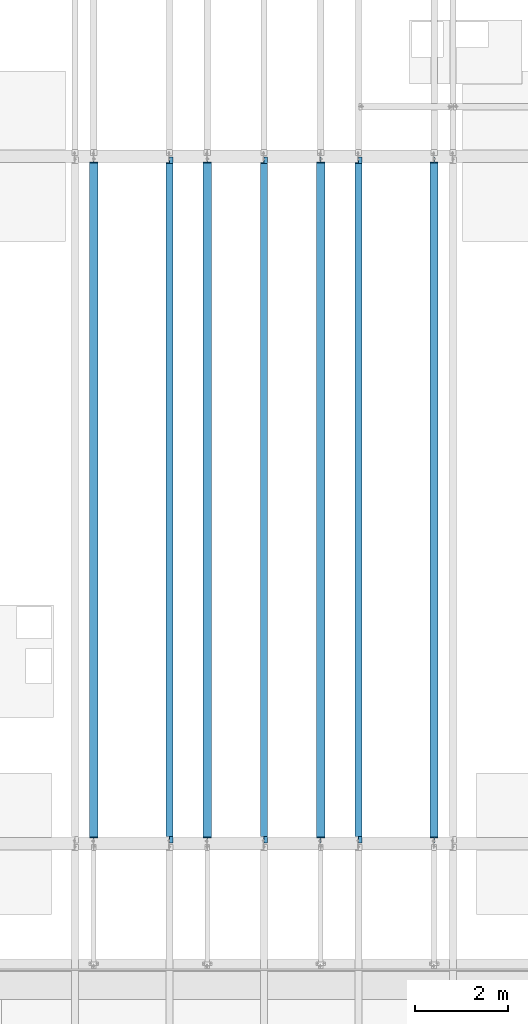
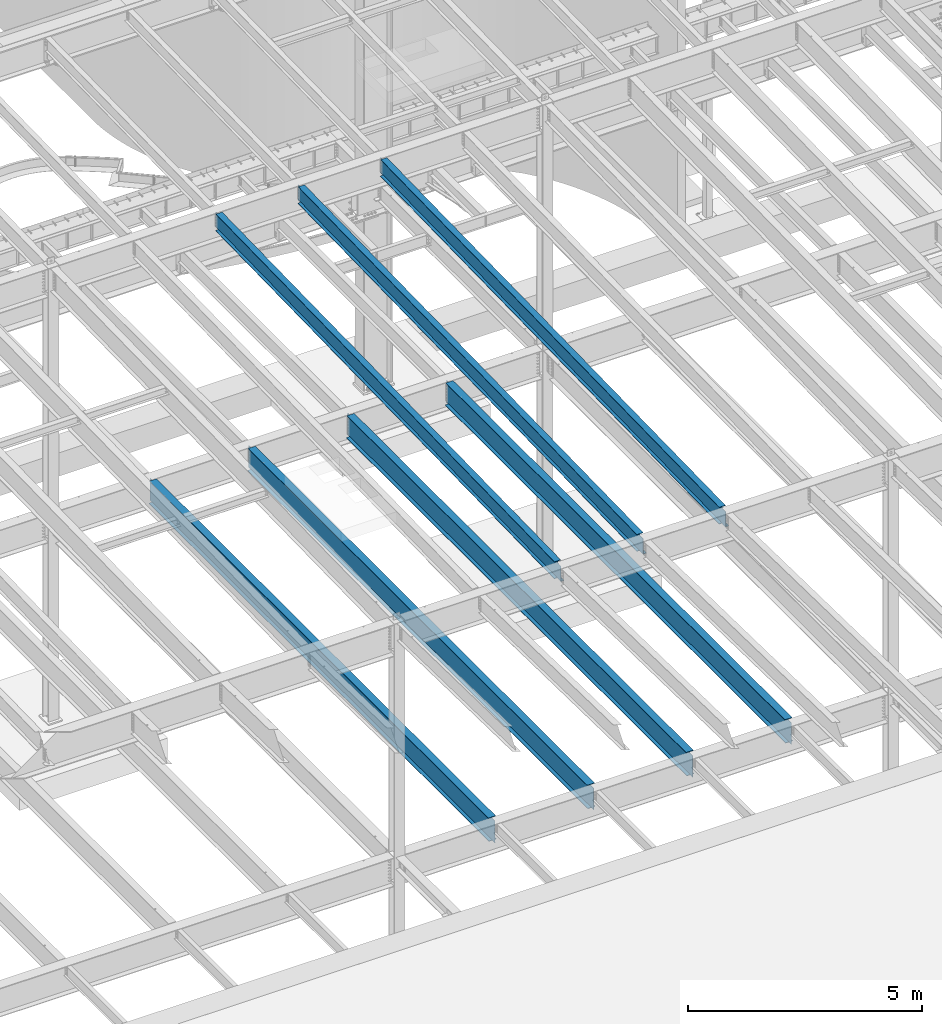
# One storey, part 1105 of 1763: 7 beams, 7 elements without a shape of their own.
"""IFC2X3 building model written with IfcOpenShell, lengths in millimetres."""

from ifc_helpers import new_model, si_unit, frame, origin_with_axes, place, context, subcontext, project, spatial, faceted_brep, material, type_object, element, aggregate, save


model = new_model("IFC2X3")

# Units and contexts
model_context = context("Model", 3, precision=1e-05, world=origin_with_axes())
body_context = subcontext(model_context, "Body", "Model", "MODEL_VIEW")
ifc_project = project(units=[si_unit("LENGTHUNIT", "METRE", prefix="MILLI"), si_unit("AREAUNIT", "SQUARE_METRE"), si_unit("VOLUMEUNIT", "CUBIC_METRE"), si_unit("MASSUNIT", "GRAM", prefix="KILO"), si_unit("TIMEUNIT", "SECOND"), si_unit("PLANEANGLEUNIT", "RADIAN"), si_unit("SOLIDANGLEUNIT", "STERADIAN"), si_unit("THERMODYNAMICTEMPERATUREUNIT", "DEGREE_CELSIUS"), si_unit("LUMINOUSINTENSITYUNIT", "LUMEN")], contexts=[model_context])

# Site, building, storey
site_placement = place(None, origin_with_axes())
site = spatial("IfcSite", under=ifc_project, at=site_placement, CompositionType="ELEMENT")
building_placement = place(site_placement, origin_with_axes())
building = spatial("IfcBuilding", under=site, at=building_placement, Name="Undefined", CompositionType="ELEMENT")
storey_placement = place(building_placement, origin_with_axes())
storey = spatial("IfcBuildingStorey", under=building, at=storey_placement, Name="Undefined", CompositionType="ELEMENT", Elevation=0.0)

# Assembly, beam
assembly_1_placement = place(storey_placement, origin_with_axes())
assembly_1 = element("IfcElementAssembly", 1, at=assembly_1_placement, inside=storey, Name="BEAM", AssemblyPlace="NOTDEFINED", PredefinedType="RIGID_FRAME")
ifc_material = material(Name="STEEL/A992")
beam_type_1 = type_object("IfcBeamType", Name="W18X35", PredefinedType="NOTDEFINED")
beam_1_placement = place(assembly_1_placement, frame((-53466.4372736983, 30027.4629676506, 11064.9232324289), z_axis=(0.0, -0.0206852279954837, 0.999786037781472), x_axis=(0.0, 0.999786037781472, 0.0206852279954825)))
beam_1 = element("IfcBeam", 2, at=beam_1_placement, type_object=beam_type_1, material=ifc_material, Name="BEAM", ObjectType="W18X35", context=body_context, shape_type="Brep", body=[
    faceted_brep([(160.440116083144, 4.26867060238874, -214.312499999869), (160.440116083122, 4.26882632548222, -225.424999999861), (9.72614572745442, 4.26881667977432, -225.424999999832), (9.95605951641846, 4.26866097140737, -214.31249999984), (160.440111479107, 76.1999999999971, -214.312499999869), (160.440111479107, 76.1999999999971, -225.424999999861), (160.440111159907, -3.96875, 187.065001487454), (160.440111159907, 3.96875, 187.065001487454), (159.47338123732, 3.96875, 182.204921969418), (159.47338123732, -3.96875, 182.204921969418), (156.720367336846, 3.96875, 178.084745501274), (156.720367336846, -3.96875, 178.084745501274), (152.600190868703, 3.96875, 175.331731600803), (152.600190868703, -3.96875, 175.331731600803), (147.740111350664, 3.96875, 174.365001678218), (147.740111350664, -3.96875, 174.365001678218), (17.9976628546319, 3.96875, 174.365001678243), (17.9976628546319, -3.96875, 174.365001678243), (9.95605951641846, -3.96875, -214.31249999984), (14757.8115434472, -3.96875, -214.312500002648), (14765.8531467846, -3.96875, 174.36500163611), (14641.5955948759, -3.96875, 174.365001636133), (14636.7355153579, -3.96875, 175.331731558719), (14632.6153388897, -3.96875, 178.084745459191), (14629.8623249892, -3.96875, 182.204921927336), (14628.8955950666, -3.96875, 187.065001445368), (14628.8955950666, -3.96875, 214.312499997053), (160.440111159915, -3.96875, 214.312499999809), (9.95605951641846, -76.1999999999971, -214.31249999984), (14757.8115434472, -76.1999999999971, -214.312500002648), (9.72614572745442, -76.1999999999971, -225.424999999832), (14757.5816296582, -76.1999999999971, -225.425000002639), (14641.5955921487, 4.26882640406257, -214.312500002627), (14641.5955921487, 4.26867068048159, -225.425000002617), (14641.5955830855, 76.1999999999971, -225.425000002617), (14641.5955830855, 76.1999999999971, -214.312500002628), (14757.8115434472, 4.26884104704368, -214.312500002648), (14757.5816296582, 4.26868529446074, -225.425000002639), (14757.8115434472, 3.96875, -214.312500002648), (14765.8531467846, 3.96875, 174.36500163611), (14641.5955948759, 3.96875, 174.365001636133), (14636.7355153579, 3.96875, 175.331731558719), (14632.6153388897, 3.96875, 178.084745459191), (14629.8623249892, 3.96875, 182.204921927336), (14628.8955950666, 3.96875, 187.065001445368), (14628.8955950666, -76.1999999999971, 225.424999997045), (14628.8955950666, -76.1999999999971, 214.312499997053), (14628.8955950666, 3.96875, 214.312499997053), (14628.8955950666, 76.1999999999971, 214.312499997053), (14628.8955950666, 76.1999999999971, 225.424999997045), (160.440111159915, 3.96875, 214.312499999809), (160.440111159915, 76.1999999999971, 214.312499999809), (160.440111159915, 76.1999999999971, 225.424999999799), (160.440111159915, -76.1999999999971, 225.424999999799), (160.440111159915, -76.1999999999971, 214.312499999809), (9.95605951641846, 3.96875, -214.31249999984)], [[[0, 1, 2, 3]], [[4, 5, 1, 0]], [[6, 7, 8, 9]], [[9, 8, 10, 11]], [[11, 10, 12, 13]], [[13, 12, 14, 15]], [[15, 14, 16, 17]], [[9, 11, 13, 15, 17, 18, 19, 20, 21, 22, 23, 24, 25, 26, 27, 6]], [[18, 28, 29, 19]], [[28, 30, 31, 29]], [[32, 33, 34, 35]], [[36, 37, 33, 32]], [[38, 39, 20, 19, 29, 31, 37, 36]], [[20, 39, 40, 21]], [[21, 40, 41, 22]], [[22, 41, 42, 23]], [[23, 42, 43, 24]], [[24, 43, 44, 25]], [[45, 46, 26, 25, 44, 47, 48, 49]], [[48, 47, 50, 51]], [[49, 48, 51, 52]], [[45, 49, 52, 53]], [[46, 45, 53, 54]], [[26, 46, 54, 27]], [[53, 52, 51, 50, 7, 6, 27, 54]], [[47, 44, 43, 42, 41, 40, 39, 38, 55, 16, 14, 12, 10, 8, 7, 50]], [[30, 28, 18, 17, 16, 55, 3, 2]], [[34, 33, 37, 31, 30, 2, 1, 5]], [[35, 34, 5, 4]], [[55, 38, 36, 32, 35, 4, 0, 3]]]),
])
aggregate(assembly_1, [beam_1])

assembly_2_placement = place(storey_placement, origin_with_axes())
assembly_2 = element("IfcElementAssembly", 3, at=assembly_2_placement, inside=storey, Name="BEAM", AssemblyPlace="NOTDEFINED", PredefinedType="RIGID_FRAME")
beam_2_placement = place(assembly_2_placement, frame((-55498.4372736983, 30027.4629676506, 11064.9232324289), z_axis=(0.0, -0.0206852279954837, 0.999786037781472), x_axis=(0.0, 0.999786037781472, 0.0206852279954825)))
beam_2 = element("IfcBeam", 4, at=beam_2_placement, type_object=beam_type_1, material=ifc_material, Name="BEAM", ObjectType="W18X35", context=body_context, shape_type="Brep", body=[
    faceted_brep([(160.440116083144, 4.26867060238874, -214.312499999869), (160.440116083122, 4.26882632548222, -225.424999999861), (9.72614572745442, 4.26881667977432, -225.424999999832), (9.95605951641846, 4.26866097140737, -214.31249999984), (160.440111479107, 76.1999999999971, -214.312499999869), (160.440111479107, 76.1999999999971, -225.424999999861), (160.440111159907, -3.96875, 187.065001487454), (160.440111159907, 3.96875, 187.065001487454), (159.47338123732, 3.96875, 182.204921969418), (159.47338123732, -3.96875, 182.204921969418), (156.720367336846, 3.96875, 178.084745501274), (156.720367336846, -3.96875, 178.084745501274), (152.600190868703, 3.96875, 175.331731600803), (152.600190868703, -3.96875, 175.331731600803), (147.740111350664, 3.96875, 174.365001678218), (147.740111350664, -3.96875, 174.365001678218), (17.9976628546319, 3.96875, 174.365001678243), (17.9976628546319, -3.96875, 174.365001678243), (9.95605951641846, -3.96875, -214.31249999984), (14757.8115434472, -3.96875, -214.312500002648), (14765.8531467846, -3.96875, 174.36500163611), (14641.5955948759, -3.96875, 174.365001636133), (14636.7355153579, -3.96875, 175.331731558719), (14632.6153388897, -3.96875, 178.084745459191), (14629.8623249892, -3.96875, 182.204921927336), (14628.8955950666, -3.96875, 187.065001445368), (14628.8955950666, -3.96875, 214.312499997053), (160.440111159915, -3.96875, 214.312499999809), (9.95605951641846, -76.1999999999971, -214.31249999984), (14757.8115434472, -76.1999999999971, -214.312500002648), (9.72614572745442, -76.1999999999971, -225.424999999832), (14757.5816296582, -76.1999999999971, -225.425000002639), (14641.5955921487, 4.26882640406257, -214.312500002627), (14641.5955921487, 4.26867068048159, -225.425000002617), (14641.5955830855, 76.1999999999971, -225.425000002617), (14641.5955830855, 76.1999999999971, -214.312500002628), (14757.8115434472, 4.26884104704368, -214.312500002648), (14757.5816296582, 4.26868529446074, -225.425000002639), (14757.8115434472, 3.96875, -214.312500002648), (14765.8531467846, 3.96875, 174.36500163611), (14641.5955948759, 3.96875, 174.365001636133), (14636.7355153579, 3.96875, 175.331731558719), (14632.6153388897, 3.96875, 178.084745459191), (14629.8623249892, 3.96875, 182.204921927336), (14628.8955950666, 3.96875, 187.065001445368), (14628.8955950666, -76.1999999999971, 225.424999997045), (14628.8955950666, -76.1999999999971, 214.312499997053), (14628.8955950666, 3.96875, 214.312499997053), (14628.8955950666, 76.1999999999971, 214.312499997053), (14628.8955950666, 76.1999999999971, 225.424999997045), (160.440111159915, 3.96875, 214.312499999809), (160.440111159915, 76.1999999999971, 214.312499999809), (160.440111159915, 76.1999999999971, 225.424999999799), (160.440111159915, -76.1999999999971, 225.424999999799), (160.440111159915, -76.1999999999971, 214.312499999809), (9.95605951641846, 3.96875, -214.31249999984)], [[[0, 1, 2, 3]], [[4, 5, 1, 0]], [[6, 7, 8, 9]], [[9, 8, 10, 11]], [[11, 10, 12, 13]], [[13, 12, 14, 15]], [[15, 14, 16, 17]], [[9, 11, 13, 15, 17, 18, 19, 20, 21, 22, 23, 24, 25, 26, 27, 6]], [[18, 28, 29, 19]], [[28, 30, 31, 29]], [[32, 33, 34, 35]], [[36, 37, 33, 32]], [[38, 39, 20, 19, 29, 31, 37, 36]], [[20, 39, 40, 21]], [[21, 40, 41, 22]], [[22, 41, 42, 23]], [[23, 42, 43, 24]], [[24, 43, 44, 25]], [[45, 46, 26, 25, 44, 47, 48, 49]], [[48, 47, 50, 51]], [[49, 48, 51, 52]], [[45, 49, 52, 53]], [[46, 45, 53, 54]], [[26, 46, 54, 27]], [[53, 52, 51, 50, 7, 6, 27, 54]], [[47, 44, 43, 42, 41, 40, 39, 38, 55, 16, 14, 12, 10, 8, 7, 50]], [[30, 28, 18, 17, 16, 55, 3, 2]], [[34, 33, 37, 31, 30, 2, 1, 5]], [[35, 34, 5, 4]], [[55, 38, 36, 32, 35, 4, 0, 3]]]),
])
aggregate(assembly_2, [beam_2])

assembly_3_placement = place(storey_placement, origin_with_axes())
assembly_3 = element("IfcElementAssembly", 5, at=assembly_3_placement, inside=storey, Name="BEAM", AssemblyPlace="NOTDEFINED", PredefinedType="RIGID_FRAME")
beam_3_placement = place(assembly_3_placement, frame((-57530.4372736983, 30027.4629676506, 11064.9232324289), z_axis=(0.0, -0.0206852279954837, 0.999786037781472), x_axis=(0.0, 0.999786037781472, 0.0206852279954825)))
beam_3 = element("IfcBeam", 6, at=beam_3_placement, type_object=beam_type_1, material=ifc_material, Name="BEAM", ObjectType="W18X35", context=body_context, shape_type="Brep", body=[
    faceted_brep([(160.440116083144, 4.26867060238874, -214.312499999869), (160.440116083122, 4.26882632548222, -225.424999999861), (9.72614572745442, 4.26881667977432, -225.424999999832), (9.95605951641846, 4.26866097140737, -214.31249999984), (160.440111479107, 76.1999999999971, -214.312499999869), (160.440111479107, 76.1999999999971, -225.424999999861), (160.440111159907, -3.96875, 187.065001487454), (160.440111159907, 3.96875, 187.065001487454), (159.47338123732, 3.96875, 182.204921969418), (159.47338123732, -3.96875, 182.204921969418), (156.720367336846, 3.96875, 178.084745501274), (156.720367336846, -3.96875, 178.084745501274), (152.600190868703, 3.96875, 175.331731600803), (152.600190868703, -3.96875, 175.331731600803), (147.740111350664, 3.96875, 174.365001678218), (147.740111350664, -3.96875, 174.365001678218), (17.9976628546319, 3.96875, 174.365001678243), (17.9976628546319, -3.96875, 174.365001678243), (9.95605951641846, -3.96875, -214.31249999984), (14757.8115434472, -3.96875, -214.312500002648), (14765.8531467846, -3.96875, 174.36500163611), (14641.5955948759, -3.96875, 174.365001636133), (14636.7355153579, -3.96875, 175.331731558719), (14632.6153388897, -3.96875, 178.084745459191), (14629.8623249892, -3.96875, 182.204921927336), (14628.8955950666, -3.96875, 187.065001445368), (14628.8955950666, -3.96875, 214.312499997053), (160.440111159915, -3.96875, 214.312499999809), (9.95605951641846, -76.1999999999971, -214.31249999984), (14757.8115434472, -76.1999999999971, -214.312500002648), (9.72614572745442, -76.1999999999971, -225.424999999832), (14757.5816296582, -76.1999999999971, -225.425000002639), (14641.5955921487, 4.26882640406257, -214.312500002627), (14641.5955921487, 4.26867068048159, -225.425000002617), (14641.5955830855, 76.1999999999971, -225.425000002617), (14641.5955830855, 76.1999999999971, -214.312500002628), (14757.8115434472, 4.26884104704368, -214.312500002648), (14757.5816296582, 4.26868529446074, -225.425000002639), (14757.8115434472, 3.96875, -214.312500002648), (14765.8531467846, 3.96875, 174.36500163611), (14641.5955948759, 3.96875, 174.365001636133), (14636.7355153579, 3.96875, 175.331731558719), (14632.6153388897, 3.96875, 178.084745459191), (14629.8623249892, 3.96875, 182.204921927336), (14628.8955950666, 3.96875, 187.065001445368), (14628.8955950666, -76.1999999999971, 225.424999997045), (14628.8955950666, -76.1999999999971, 214.312499997053), (14628.8955950666, 3.96875, 214.312499997053), (14628.8955950666, 76.1999999999971, 214.312499997053), (14628.8955950666, 76.1999999999971, 225.424999997045), (160.440111159915, 3.96875, 214.312499999809), (160.440111159915, 76.1999999999971, 214.312499999809), (160.440111159915, 76.1999999999971, 225.424999999799), (160.440111159915, -76.1999999999971, 225.424999999799), (160.440111159915, -76.1999999999971, 214.312499999809), (9.95605951641846, 3.96875, -214.31249999984)], [[[0, 1, 2, 3]], [[4, 5, 1, 0]], [[6, 7, 8, 9]], [[9, 8, 10, 11]], [[11, 10, 12, 13]], [[13, 12, 14, 15]], [[15, 14, 16, 17]], [[9, 11, 13, 15, 17, 18, 19, 20, 21, 22, 23, 24, 25, 26, 27, 6]], [[18, 28, 29, 19]], [[28, 30, 31, 29]], [[32, 33, 34, 35]], [[36, 37, 33, 32]], [[38, 39, 20, 19, 29, 31, 37, 36]], [[20, 39, 40, 21]], [[21, 40, 41, 22]], [[22, 41, 42, 23]], [[23, 42, 43, 24]], [[24, 43, 44, 25]], [[45, 46, 26, 25, 44, 47, 48, 49]], [[48, 47, 50, 51]], [[49, 48, 51, 52]], [[45, 49, 52, 53]], [[46, 45, 53, 54]], [[26, 46, 54, 27]], [[53, 52, 51, 50, 7, 6, 27, 54]], [[47, 44, 43, 42, 41, 40, 39, 38, 55, 16, 14, 12, 10, 8, 7, 50]], [[30, 28, 18, 17, 16, 55, 3, 2]], [[34, 33, 37, 31, 30, 2, 1, 5]], [[35, 34, 5, 4]], [[55, 38, 36, 32, 35, 4, 0, 3]]]),
])
aggregate(assembly_3, [beam_3])

assembly_4_placement = place(storey_placement, origin_with_axes())
assembly_4 = element("IfcElementAssembly", 7, at=assembly_4_placement, inside=storey, Name="BEAM", AssemblyPlace="NOTDEFINED", PredefinedType="RIGID_FRAME")
beam_type_2 = type_object("IfcBeamType", Name="W24X55", PredefinedType="NOTDEFINED")
beam_4_placement = place(assembly_4_placement, frame((-51840.8372736984, 30022.8, 4894.2625), z_axis=(0.0, 0.0, 1.0), x_axis=(0.0, 1.0, 0.0)))
beam_4 = element("IfcBeam", 8, at=beam_4_placement, type_object=beam_type_2, material=ifc_material, Name="BEAM", ObjectType="W24X55", context=body_context, shape_type="Brep", body=[
    faceted_brep([(19.0499999999993, -5.06263026501983, -287.3375), (19.0499999999993, -5.06239088271832, -300.0375), (120.650010238503, -5.06237879249238, -300.0375), (120.650010238547, -5.06261817480845, -287.3375), (120.650020215031, -88.9000000000015, -287.3375), (120.650020215031, -88.9000000000015, -300.0375), (146.049999999999, -4.76249999999709, 280.727501487732), (146.049999999999, 4.76249999999709, 280.727501487732), (145.083270077412, 4.76249999999709, 275.867421969687), (145.083270077412, -4.76249999999709, 275.867421969687), (142.330256176934, 4.76249999999709, 271.747245501533), (142.330256176934, -4.76249999999709, 271.747245501533), (138.210079708781, 4.76249999999709, 268.994231601055), (138.210079708781, -4.76249999999709, 268.994231601055), (133.350000190734, 4.76249999999709, 268.027501678467), (133.350000190734, -4.76249999999709, 268.027501678467), (19.0499999999993, 4.76249999999709, 268.027501678467), (19.0499999999993, -4.76249999999709, 268.027501678467), (19.0499999999993, -4.76249999999709, -287.3375), (14763.75, -4.76249999999709, -287.3375), (14763.75, -4.76249999999709, 268.027501678466), (14649.4499998093, -4.76249999999709, 268.027501678466), (14644.5899202912, -4.76249999999709, 268.994231601054), (14640.4697438231, -4.76249999999709, 271.747245501532), (14637.7167299226, -4.76249999999709, 275.867421969686), (14636.75, -4.76249999999709, 280.727501487731), (14636.75, -4.76249999999709, 287.3375), (146.049999999999, -4.76249999999709, 287.3375), (14763.75, 4.76249999999709, 268.027501678466), (14649.4499998093, 4.76249999999709, 268.027501678466), (14644.5899202912, 4.76249999999709, 268.994231601054), (14640.4697438231, 4.76249999999709, 271.747245501532), (14637.7167299226, 4.76249999999709, 275.867421969686), (14636.75, 4.76249999999709, 280.727501487731), (14636.75, -88.9000000000015, 300.0375), (14636.75, -88.9000000000015, 287.3375), (14636.75, 4.76249999999709, 287.3375), (14636.75, 88.9000000000015, 287.3375), (14636.75, 88.9000000000015, 300.0375), (146.049999999999, 4.76249999999709, 287.3375), (146.049999999999, 88.9000000000015, 287.3375), (146.049999999999, 88.9000000000015, 300.0375), (146.049999999999, -88.9000000000015, 300.0375), (146.049999999999, -88.9000000000015, 287.3375), (14763.75, 4.76249999999709, -287.3375), (19.0499999999993, 4.76249999999709, -287.3375), (14763.75, 5.06263026504894, -287.3375), (14662.1499897615, 5.06261817483755, -287.3375), (14662.1499797849, 88.9000000000015, -287.3375), (120.650000595357, 88.9000000000015, -287.3375), (120.650010572102, 5.06237876442901, -287.3375), (19.0499999999993, 5.06236667421763, -287.3375), (120.650010572055, 5.06261814674508, -300.0375), (19.0499999999993, 5.06260605652642, -300.0375), (120.650000595357, 88.9000000000015, -300.0375), (14662.1499797849, 88.9000000000015, -300.0375), (14662.1499897615, 5.06237879252149, -300.0375), (14763.75, 5.06239088274742, -300.0375), (14763.75, -5.06236667417397, -287.3375), (14763.75, -5.06260605648276, -300.0375), (14662.1499894279, -5.06237876438536, -287.3375), (14662.1499894279, -5.06261814670142, -300.0375), (14662.1499994046, -88.9000000000015, -287.3375), (14662.1499994046, -88.9000000000015, -300.0375)], [[[0, 1, 2, 3]], [[4, 3, 2, 5]], [[6, 7, 8, 9]], [[9, 8, 10, 11]], [[11, 10, 12, 13]], [[13, 12, 14, 15]], [[15, 14, 16, 17]], [[9, 11, 13, 15, 17, 18, 19, 20, 21, 22, 23, 24, 25, 26, 27, 6]], [[20, 28, 29, 21]], [[21, 29, 30, 22]], [[22, 30, 31, 23]], [[23, 31, 32, 24]], [[24, 32, 33, 25]], [[34, 35, 26, 25, 33, 36, 37, 38]], [[37, 36, 39, 40]], [[38, 37, 40, 41]], [[34, 38, 41, 42]], [[35, 34, 42, 43]], [[26, 35, 43, 27]], [[42, 41, 40, 39, 7, 6, 27, 43]], [[36, 33, 32, 31, 30, 29, 28, 44, 45, 16, 14, 12, 10, 8, 7, 39]], [[45, 44, 46, 47, 48, 49, 50, 51]], [[50, 52, 53, 51]], [[49, 54, 52, 50]], [[48, 55, 54, 49]], [[47, 56, 55, 48]], [[46, 57, 56, 47]], [[44, 28, 20, 19, 58, 59, 57, 46]], [[58, 60, 61, 59]], [[62, 63, 61, 60]], [[63, 62, 4, 5]], [[1, 53, 52, 54, 55, 56, 57, 59, 61, 63, 5, 2]], [[18, 17, 16, 45, 51, 53, 1, 0]], [[62, 60, 58, 19, 18, 0, 3, 4]]]),
])
aggregate(assembly_4, [beam_4])

assembly_5_placement = place(storey_placement, origin_with_axes())
assembly_5 = element("IfcElementAssembly", 9, at=assembly_5_placement, inside=storey, Name="BEAM", AssemblyPlace="NOTDEFINED", PredefinedType="RIGID_FRAME")
beam_5_placement = place(assembly_5_placement, frame((-54279.2372736983, 30022.8, 4894.2625), z_axis=(0.0, 0.0, 1.0), x_axis=(0.0, 1.0, 0.0)))
beam_5 = element("IfcBeam", 10, at=beam_5_placement, type_object=beam_type_2, material=ifc_material, Name="BEAM", ObjectType="W24X55", context=body_context, shape_type="Brep", body=[
    faceted_brep([(19.0499999999993, -5.06263026501983, -287.3375), (19.0499999999993, -5.06239088271832, -300.0375), (120.650010238503, -5.06237879249238, -300.0375), (120.650010238547, -5.06261817480845, -287.3375), (120.650020215031, -88.9000000000015, -287.3375), (120.650020215031, -88.9000000000015, -300.0375), (146.049999999999, -4.76249999999709, 280.727501487732), (146.049999999999, 4.76249999999709, 280.727501487732), (145.083270077412, 4.76249999999709, 275.867421969687), (145.083270077412, -4.76249999999709, 275.867421969687), (142.330256176934, 4.76249999999709, 271.747245501533), (142.330256176934, -4.76249999999709, 271.747245501533), (138.210079708781, 4.76249999999709, 268.994231601055), (138.210079708781, -4.76249999999709, 268.994231601055), (133.350000190734, 4.76249999999709, 268.027501678467), (133.350000190734, -4.76249999999709, 268.027501678467), (19.0499999999993, 4.76249999999709, 268.027501678467), (19.0499999999993, -4.76249999999709, 268.027501678467), (19.0499999999993, -4.76249999999709, -287.3375), (14763.75, -4.76249999999709, -287.3375), (14763.75, -4.76249999999709, 268.027501678466), (14649.4499998093, -4.76249999999709, 268.027501678466), (14644.5899202912, -4.76249999999709, 268.994231601054), (14640.4697438231, -4.76249999999709, 271.747245501532), (14637.7167299226, -4.76249999999709, 275.867421969686), (14636.75, -4.76249999999709, 280.727501487731), (14636.75, -4.76249999999709, 287.3375), (146.049999999999, -4.76249999999709, 287.3375), (14763.75, 4.76249999999709, 268.027501678466), (14649.4499998093, 4.76249999999709, 268.027501678466), (14644.5899202912, 4.76249999999709, 268.994231601054), (14640.4697438231, 4.76249999999709, 271.747245501532), (14637.7167299226, 4.76249999999709, 275.867421969686), (14636.75, 4.76249999999709, 280.727501487731), (14636.75, -88.9000000000015, 300.0375), (14636.75, -88.9000000000015, 287.3375), (14636.75, 4.76249999999709, 287.3375), (14636.75, 88.9000000000015, 287.3375), (14636.75, 88.9000000000015, 300.0375), (146.049999999999, 4.76249999999709, 287.3375), (146.049999999999, 88.9000000000015, 287.3375), (146.049999999999, 88.9000000000015, 300.0375), (146.049999999999, -88.9000000000015, 300.0375), (146.049999999999, -88.9000000000015, 287.3375), (14763.75, 4.76249999999709, -287.3375), (19.0499999999993, 4.76249999999709, -287.3375), (14763.75, 5.06263026504894, -287.3375), (14662.1499897615, 5.06261817483755, -287.3375), (14662.1499797849, 88.9000000000015, -287.3375), (120.650000595357, 88.9000000000015, -287.3375), (120.650010572102, 5.06237876442901, -287.3375), (19.0499999999993, 5.06236667421763, -287.3375), (120.650010572055, 5.06261814674508, -300.0375), (19.0499999999993, 5.06260605652642, -300.0375), (120.650000595357, 88.9000000000015, -300.0375), (14662.1499797849, 88.9000000000015, -300.0375), (14662.1499897615, 5.06237879252149, -300.0375), (14763.75, 5.06239088274742, -300.0375), (14763.75, -5.06236667417397, -287.3375), (14763.75, -5.06260605648276, -300.0375), (14662.1499894279, -5.06237876438536, -287.3375), (14662.1499894279, -5.06261814670142, -300.0375), (14662.1499994046, -88.9000000000015, -287.3375), (14662.1499994046, -88.9000000000015, -300.0375)], [[[0, 1, 2, 3]], [[4, 3, 2, 5]], [[6, 7, 8, 9]], [[9, 8, 10, 11]], [[11, 10, 12, 13]], [[13, 12, 14, 15]], [[15, 14, 16, 17]], [[9, 11, 13, 15, 17, 18, 19, 20, 21, 22, 23, 24, 25, 26, 27, 6]], [[20, 28, 29, 21]], [[21, 29, 30, 22]], [[22, 30, 31, 23]], [[23, 31, 32, 24]], [[24, 32, 33, 25]], [[34, 35, 26, 25, 33, 36, 37, 38]], [[37, 36, 39, 40]], [[38, 37, 40, 41]], [[34, 38, 41, 42]], [[35, 34, 42, 43]], [[26, 35, 43, 27]], [[42, 41, 40, 39, 7, 6, 27, 43]], [[36, 33, 32, 31, 30, 29, 28, 44, 45, 16, 14, 12, 10, 8, 7, 39]], [[45, 44, 46, 47, 48, 49, 50, 51]], [[50, 52, 53, 51]], [[49, 54, 52, 50]], [[48, 55, 54, 49]], [[47, 56, 55, 48]], [[46, 57, 56, 47]], [[44, 28, 20, 19, 58, 59, 57, 46]], [[58, 60, 61, 59]], [[62, 63, 61, 60]], [[63, 62, 4, 5]], [[1, 53, 52, 54, 55, 56, 57, 59, 61, 63, 5, 2]], [[18, 17, 16, 45, 51, 53, 1, 0]], [[62, 60, 58, 19, 18, 0, 3, 4]]]),
])
aggregate(assembly_5, [beam_5])

assembly_6_placement = place(storey_placement, origin_with_axes())
assembly_6 = element("IfcElementAssembly", 11, at=assembly_6_placement, inside=storey, Name="BEAM", AssemblyPlace="NOTDEFINED", PredefinedType="RIGID_FRAME")
beam_6_placement = place(assembly_6_placement, frame((-56717.6372736983, 30022.8, 4894.2625), z_axis=(0.0, 0.0, 1.0), x_axis=(0.0, 1.0, 0.0)))
beam_6 = element("IfcBeam", 12, at=beam_6_placement, type_object=beam_type_2, material=ifc_material, Name="BEAM", ObjectType="W24X55", context=body_context, shape_type="Brep", body=[
    faceted_brep([(19.0499999999993, -5.06263026501983, -287.3375), (19.0499999999993, -5.06239088271832, -300.0375), (120.650010238503, -5.06237879249238, -300.0375), (120.650010238547, -5.06261817480845, -287.3375), (120.650020215031, -88.9000000000015, -287.3375), (120.650020215031, -88.9000000000015, -300.0375), (146.049999999999, -4.76249999999709, 280.727501487732), (146.049999999999, 4.76249999999709, 280.727501487732), (145.083270077412, 4.76249999999709, 275.867421969687), (145.083270077412, -4.76249999999709, 275.867421969687), (142.330256176934, 4.76249999999709, 271.747245501533), (142.330256176934, -4.76249999999709, 271.747245501533), (138.210079708781, 4.76249999999709, 268.994231601055), (138.210079708781, -4.76249999999709, 268.994231601055), (133.350000190734, 4.76249999999709, 268.027501678467), (133.350000190734, -4.76249999999709, 268.027501678467), (19.0499999999993, 4.76249999999709, 268.027501678467), (19.0499999999993, -4.76249999999709, 268.027501678467), (19.0499999999993, -4.76249999999709, -287.3375), (14763.75, -4.76249999999709, -287.3375), (14763.75, -4.76249999999709, 268.027501678466), (14649.4499998093, -4.76249999999709, 268.027501678466), (14644.5899202912, -4.76249999999709, 268.994231601054), (14640.4697438231, -4.76249999999709, 271.747245501532), (14637.7167299226, -4.76249999999709, 275.867421969686), (14636.75, -4.76249999999709, 280.727501487731), (14636.75, -4.76249999999709, 287.3375), (146.049999999999, -4.76249999999709, 287.3375), (14763.75, 4.76249999999709, 268.027501678466), (14649.4499998093, 4.76249999999709, 268.027501678466), (14644.5899202912, 4.76249999999709, 268.994231601054), (14640.4697438231, 4.76249999999709, 271.747245501532), (14637.7167299226, 4.76249999999709, 275.867421969686), (14636.75, 4.76249999999709, 280.727501487731), (14636.75, -88.9000000000015, 300.0375), (14636.75, -88.9000000000015, 287.3375), (14636.75, 4.76249999999709, 287.3375), (14636.75, 88.9000000000015, 287.3375), (14636.75, 88.9000000000015, 300.0375), (146.049999999999, 4.76249999999709, 287.3375), (146.049999999999, 88.9000000000015, 287.3375), (146.049999999999, 88.9000000000015, 300.0375), (146.049999999999, -88.9000000000015, 300.0375), (146.049999999999, -88.9000000000015, 287.3375), (14763.75, 4.76249999999709, -287.3375), (19.0499999999993, 4.76249999999709, -287.3375), (14763.75, 5.06263026504894, -287.3375), (14662.1499897615, 5.06261817483755, -287.3375), (14662.1499797849, 88.9000000000015, -287.3375), (120.650000595357, 88.9000000000015, -287.3375), (120.650010572102, 5.06237876442901, -287.3375), (19.0499999999993, 5.06236667421763, -287.3375), (120.650010572055, 5.06261814674508, -300.0375), (19.0499999999993, 5.06260605652642, -300.0375), (120.650000595357, 88.9000000000015, -300.0375), (14662.1499797849, 88.9000000000015, -300.0375), (14662.1499897615, 5.06237879252149, -300.0375), (14763.75, 5.06239088274742, -300.0375), (14763.75, -5.06236667417397, -287.3375), (14763.75, -5.06260605648276, -300.0375), (14662.1499894279, -5.06237876438536, -287.3375), (14662.1499894279, -5.06261814670142, -300.0375), (14662.1499994046, -88.9000000000015, -287.3375), (14662.1499994046, -88.9000000000015, -300.0375)], [[[0, 1, 2, 3]], [[4, 3, 2, 5]], [[6, 7, 8, 9]], [[9, 8, 10, 11]], [[11, 10, 12, 13]], [[13, 12, 14, 15]], [[15, 14, 16, 17]], [[9, 11, 13, 15, 17, 18, 19, 20, 21, 22, 23, 24, 25, 26, 27, 6]], [[20, 28, 29, 21]], [[21, 29, 30, 22]], [[22, 30, 31, 23]], [[23, 31, 32, 24]], [[24, 32, 33, 25]], [[34, 35, 26, 25, 33, 36, 37, 38]], [[37, 36, 39, 40]], [[38, 37, 40, 41]], [[34, 38, 41, 42]], [[35, 34, 42, 43]], [[26, 35, 43, 27]], [[42, 41, 40, 39, 7, 6, 27, 43]], [[36, 33, 32, 31, 30, 29, 28, 44, 45, 16, 14, 12, 10, 8, 7, 39]], [[45, 44, 46, 47, 48, 49, 50, 51]], [[50, 52, 53, 51]], [[49, 54, 52, 50]], [[48, 55, 54, 49]], [[47, 56, 55, 48]], [[46, 57, 56, 47]], [[44, 28, 20, 19, 58, 59, 57, 46]], [[58, 60, 61, 59]], [[62, 63, 61, 60]], [[63, 62, 4, 5]], [[1, 53, 52, 54, 55, 56, 57, 59, 61, 63, 5, 2]], [[18, 17, 16, 45, 51, 53, 1, 0]], [[62, 60, 58, 19, 18, 0, 3, 4]]]),
])
aggregate(assembly_6, [beam_6])

assembly_7_placement = place(storey_placement, origin_with_axes())
assembly_7 = element("IfcElementAssembly", 13, at=assembly_7_placement, inside=storey, Name="BEAM", AssemblyPlace="NOTDEFINED", PredefinedType="RIGID_FRAME")
beam_7_placement = place(assembly_7_placement, frame((-59156.0372736983, 30022.8, 4894.2625), z_axis=(0.0, 0.0, 1.0), x_axis=(0.0, 1.0, 0.0)))
beam_7 = element("IfcBeam", 14, at=beam_7_placement, type_object=beam_type_2, material=ifc_material, Name="BEAM", ObjectType="W24X55", context=body_context, shape_type="Brep", body=[
    faceted_brep([(19.0499999999993, -5.06263026501983, -287.3375), (19.0499999999993, -5.06239088271832, -300.0375), (120.650010238503, -5.06237879249238, -300.0375), (120.650010238547, -5.06261817480845, -287.3375), (120.650020215031, -88.9000000000015, -287.3375), (120.650020215031, -88.9000000000015, -300.0375), (146.049999999999, -4.76249999999709, 280.727501487732), (146.049999999999, 4.76249999999709, 280.727501487732), (145.083270077412, 4.76249999999709, 275.867421969687), (145.083270077412, -4.76249999999709, 275.867421969687), (142.330256176934, 4.76249999999709, 271.747245501533), (142.330256176934, -4.76249999999709, 271.747245501533), (138.210079708781, 4.76249999999709, 268.994231601055), (138.210079708781, -4.76249999999709, 268.994231601055), (133.350000190734, 4.76249999999709, 268.027501678467), (133.350000190734, -4.76249999999709, 268.027501678467), (19.0499999999993, 4.76249999999709, 268.027501678467), (19.0499999999993, -4.76249999999709, 268.027501678467), (19.0499999999993, -4.76249999999709, -287.3375), (14763.75, -4.76249999999709, -287.3375), (14763.75, -4.76249999999709, 268.027501678466), (14649.4499998093, -4.76249999999709, 268.027501678466), (14644.5899202912, -4.76249999999709, 268.994231601054), (14640.4697438231, -4.76249999999709, 271.747245501532), (14637.7167299226, -4.76249999999709, 275.867421969686), (14636.75, -4.76249999999709, 280.727501487731), (14636.75, -4.76249999999709, 287.3375), (146.049999999999, -4.76249999999709, 287.3375), (14763.75, 4.76249999999709, 268.027501678466), (14649.4499998093, 4.76249999999709, 268.027501678466), (14644.5899202912, 4.76249999999709, 268.994231601054), (14640.4697438231, 4.76249999999709, 271.747245501532), (14637.7167299226, 4.76249999999709, 275.867421969686), (14636.75, 4.76249999999709, 280.727501487731), (14636.75, -88.9000000000015, 300.0375), (14636.75, -88.9000000000015, 287.3375), (14636.75, 4.76249999999709, 287.3375), (14636.75, 88.9000000000015, 287.3375), (14636.75, 88.9000000000015, 300.0375), (146.049999999999, 4.76249999999709, 287.3375), (146.049999999999, 88.9000000000015, 287.3375), (146.049999999999, 88.9000000000015, 300.0375), (146.049999999999, -88.9000000000015, 300.0375), (146.049999999999, -88.9000000000015, 287.3375), (14763.75, 4.76249999999709, -287.3375), (19.0499999999993, 4.76249999999709, -287.3375), (14763.75, 5.06263026504894, -287.3375), (14662.1499897615, 5.06261817483755, -287.3375), (14662.1499797849, 88.9000000000015, -287.3375), (120.650000595357, 88.9000000000015, -287.3375), (120.650010572102, 5.06237876442901, -287.3375), (19.0499999999993, 5.06236667421763, -287.3375), (120.650010572055, 5.06261814674508, -300.0375), (19.0499999999993, 5.06260605652642, -300.0375), (120.650000595357, 88.9000000000015, -300.0375), (14662.1499797849, 88.9000000000015, -300.0375), (14662.1499897615, 5.06237879252149, -300.0375), (14763.75, 5.06239088274742, -300.0375), (14763.75, -5.06236667417397, -287.3375), (14763.75, -5.06260605648276, -300.0375), (14662.1499894279, -5.06237876438536, -287.3375), (14662.1499894279, -5.06261814670142, -300.0375), (14662.1499994046, -88.9000000000015, -287.3375), (14662.1499994046, -88.9000000000015, -300.0375)], [[[0, 1, 2, 3]], [[4, 3, 2, 5]], [[6, 7, 8, 9]], [[9, 8, 10, 11]], [[11, 10, 12, 13]], [[13, 12, 14, 15]], [[15, 14, 16, 17]], [[9, 11, 13, 15, 17, 18, 19, 20, 21, 22, 23, 24, 25, 26, 27, 6]], [[20, 28, 29, 21]], [[21, 29, 30, 22]], [[22, 30, 31, 23]], [[23, 31, 32, 24]], [[24, 32, 33, 25]], [[34, 35, 26, 25, 33, 36, 37, 38]], [[37, 36, 39, 40]], [[38, 37, 40, 41]], [[34, 38, 41, 42]], [[35, 34, 42, 43]], [[26, 35, 43, 27]], [[42, 41, 40, 39, 7, 6, 27, 43]], [[36, 33, 32, 31, 30, 29, 28, 44, 45, 16, 14, 12, 10, 8, 7, 39]], [[45, 44, 46, 47, 48, 49, 50, 51]], [[50, 52, 53, 51]], [[49, 54, 52, 50]], [[48, 55, 54, 49]], [[47, 56, 55, 48]], [[46, 57, 56, 47]], [[44, 28, 20, 19, 58, 59, 57, 46]], [[58, 60, 61, 59]], [[62, 63, 61, 60]], [[63, 62, 4, 5]], [[1, 53, 52, 54, 55, 56, 57, 59, 61, 63, 5, 2]], [[18, 17, 16, 45, 51, 53, 1, 0]], [[62, 60, 58, 19, 18, 0, 3, 4]]]),
])
aggregate(assembly_7, [beam_7])

save(model, "model.ifc")
